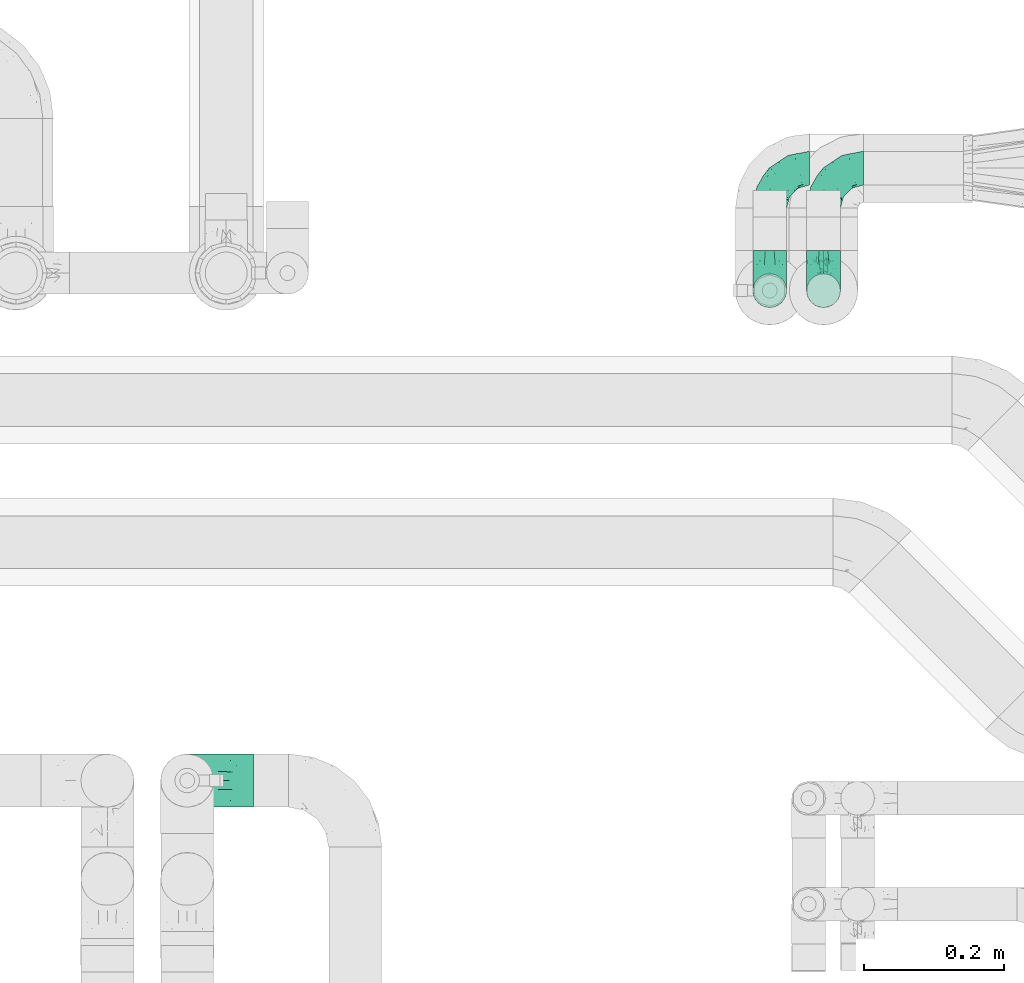
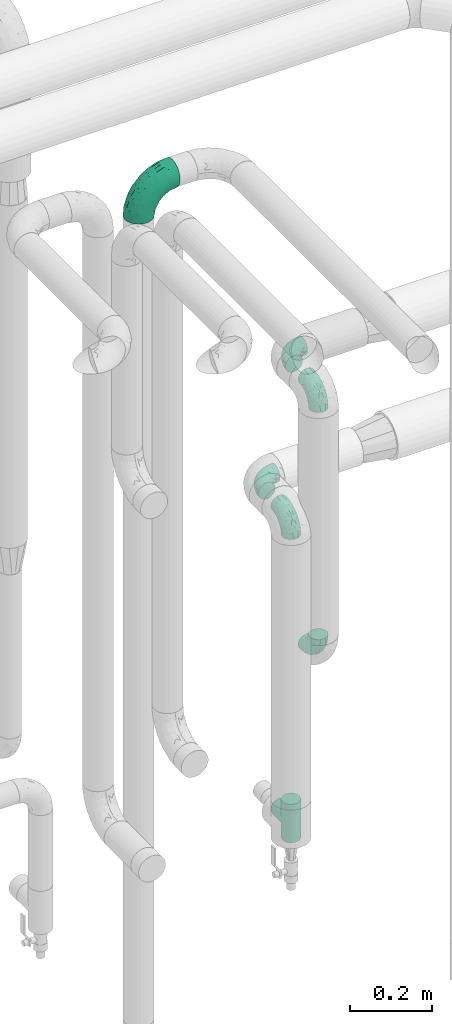
# One storey, part 681 of 824: 7 flow fittings.
"""IFC2X3 building model written with IfcOpenShell, lengths in millimetres."""

from ifc_helpers import new_model, entity, si_unit, converted_unit, derived_unit, direction, frame, origin, place, context, subcontext, project, spatial, faceted_brep, source, transform, mapped, material, type_object, type_shapes, element, save


model = new_model("IFC2X3")

# Units and contexts
model_context = context("Model", 3, precision=0.01, world=origin(), true_north=direction((6.12303176911189e-17, 1.0)))
body_context = subcontext(model_context, "Body", "Model", "MODEL_VIEW")
ifc_project = project(units=[si_unit("LENGTHUNIT", "METRE", prefix="MILLI"), si_unit("AREAUNIT", "SQUARE_METRE"), si_unit("VOLUMEUNIT", "CUBIC_METRE"), converted_unit("PLANEANGLEUNIT", "DEGREE", entity("IfcRatioMeasure", 0.0174532925199433), si_unit("PLANEANGLEUNIT", "RADIAN"), dimensions=[0, 0, 0, 0, 0, 0, 0]), si_unit("MASSUNIT", "GRAM", prefix="KILO"), derived_unit("MASSDENSITYUNIT", [(si_unit("MASSUNIT", "GRAM", prefix="KILO"), 1), (si_unit("LENGTHUNIT", "METRE"), -3)]), derived_unit("MOMENTOFINERTIAUNIT", [(si_unit("LENGTHUNIT", "METRE"), 4)]), si_unit("TIMEUNIT", "SECOND"), si_unit("FREQUENCYUNIT", "HERTZ"), si_unit("THERMODYNAMICTEMPERATUREUNIT", "DEGREE_CELSIUS"), derived_unit("THERMALTRANSMITTANCEUNIT", [(si_unit("MASSUNIT", "GRAM", prefix="KILO"), 1), (si_unit("THERMODYNAMICTEMPERATUREUNIT", "KELVIN"), -1), (si_unit("TIMEUNIT", "SECOND"), -3)]), derived_unit("VOLUMETRICFLOWRATEUNIT", [(si_unit("LENGTHUNIT", "METRE"), 3), (si_unit("TIMEUNIT", "SECOND"), -1)]), derived_unit("MASSFLOWRATEUNIT", [(si_unit("MASSUNIT", "GRAM", prefix="KILO"), 1), (si_unit("TIMEUNIT", "SECOND"), -1)]), derived_unit("ROTATIONALFREQUENCYUNIT", [(si_unit("TIMEUNIT", "SECOND"), -1)]), si_unit("ELECTRICCURRENTUNIT", "AMPERE"), si_unit("ELECTRICVOLTAGEUNIT", "VOLT"), si_unit("POWERUNIT", "WATT"), si_unit("FORCEUNIT", "NEWTON", prefix="KILO"), si_unit("ILLUMINANCEUNIT", "LUX"), si_unit("LUMINOUSFLUXUNIT", "LUMEN"), si_unit("LUMINOUSINTENSITYUNIT", "CANDELA"), derived_unit("USERDEFINED", [(si_unit("MASSUNIT", "GRAM", prefix="KILO"), -1), (si_unit("LENGTHUNIT", "METRE"), -2), (si_unit("TIMEUNIT", "SECOND"), 3), (si_unit("LUMINOUSFLUXUNIT", "LUMEN"), 1)]), derived_unit("LINEARVELOCITYUNIT", [(si_unit("LENGTHUNIT", "METRE"), 1), (si_unit("TIMEUNIT", "SECOND"), -1)]), si_unit("PRESSUREUNIT", "PASCAL"), derived_unit("USERDEFINED", [(si_unit("LENGTHUNIT", "METRE"), -2), (si_unit("MASSUNIT", "GRAM", prefix="KILO"), 1), (si_unit("TIMEUNIT", "SECOND"), -2)]), derived_unit("LINEARFORCEUNIT", [(si_unit("MASSUNIT", "GRAM", prefix="KILO"), 1), (si_unit("LENGTHUNIT", "METRE"), 1), (si_unit("TIMEUNIT", "SECOND"), -2), (si_unit("LENGTHUNIT", "METRE"), -1)]), derived_unit("PLANARFORCEUNIT", [(si_unit("MASSUNIT", "GRAM", prefix="KILO"), 1), (si_unit("LENGTHUNIT", "METRE"), 1), (si_unit("TIMEUNIT", "SECOND"), -2), (si_unit("LENGTHUNIT", "METRE"), -2)])], contexts=[model_context])

# Site, building, storey
site_placement = place(None, origin())
site = spatial("IfcSite", under=ifc_project, at=site_placement, CompositionType="ELEMENT")
building_placement = place(site_placement, origin())
building = spatial("IfcBuilding", under=site, at=building_placement, CompositionType="ELEMENT")
storey_placement = place(building_placement, frame((0.0, 0.0, 28200.0)))
storey = spatial("IfcBuildingStorey", under=building, at=storey_placement, CompositionType="ELEMENT", Elevation=28200.0)

# Flow fittings
ifc_material = material()
pipe_fitting_type_1 = type_object("IfcPipeFittingType", PredefinedType="NOTDEFINED", material=ifc_material)
shared_shape_1 = source(origin(), body_context, "Body", "Brep", [
    faceted_brep([(-57.0, 12.07, -20.91), (-57.0, 6.25, -23.33), (-57.0, 0.0, -24.15), (-57.0, -6.25, -23.33), (-57.0, -12.08, -20.91), (-57.0, -17.08, -17.08), (-57.0, -20.91, -12.08), (-57.0, -23.33, -6.25), (-57.0, -24.15, 0.0), (-57.0, -23.33, 6.25), (-57.0, -20.91, 12.07), (-57.0, -17.08, 17.08), (-57.0, -12.08, 20.91), (-57.0, -6.25, 23.33), (-57.0, 0.0, 24.15), (-57.0, 6.25, 23.33), (-57.0, 12.07, 20.91), (-57.0, 17.08, 17.08), (-57.0, 20.91, 12.07), (-57.0, 23.33, 6.25), (-57.0, 24.15, 0.0), (-57.0, 23.33, -6.25), (-57.0, 20.91, -12.08), (-57.0, 17.08, -17.08), (0.0, 57.0, -24.15), (-6.25, 57.0, -23.33), (-12.07, 57.0, -20.91), (-17.08, 57.0, -17.08), (-20.91, 57.0, -12.08), (-23.33, 57.0, -6.25), (-24.15, 57.0, 0.0), (-23.33, 57.0, 6.25), (-20.91, 57.0, 12.07), (-17.08, 57.0, 17.08), (-12.07, 57.0, 20.91), (-6.25, 57.0, 23.33), (0.0, 57.0, 24.15), (6.25, 57.0, 23.33), (12.08, 57.0, 20.91), (17.08, 57.0, 17.08), (20.91, 57.0, 12.07), (23.33, 57.0, 6.25), (24.15, 57.0, 0.0), (23.33, 57.0, -6.25), (20.91, 57.0, -12.08), (17.08, 57.0, -17.08), (12.08, 57.0, -20.91), (6.25, 57.0, -23.33), (14.9, 21.14, 6.17), (13.61, 24.64, 12.48), (6.23, 8.95, 8.98), (-41.47, -21.06, 0.0), (-41.92, -18.38, 13.72), (-24.64, -13.61, 12.48), (-37.37, -13.24, 18.15), (-6.8, -4.93, 8.18), (-21.76, -15.19, 6.22), (-12.78, -9.18, 0.0), (-37.73, -20.51, 7.75), (-7.38, 7.38, 20.24), (-23.37, -4.26, 20.42), (-11.9, -3.19, 15.86), (-42.14, -8.7, 21.82), (13.24, 37.37, 18.15), (9.33, 23.53, 16.85), (4.26, 23.37, 20.42), (2.77, 10.92, 15.55), (-29.46, 0.91, 23.52), (-44.13, 20.56, 15.69), (-39.25, 26.33, 10.88), (-49.02, 22.92, 9.96), (-34.58, 23.87, 17.15), (-15.8, 6.8, 22.81), (-8.67, 20.47, 23.88), (-18.12, 12.9, 24.08), (-48.29, 14.92, 19.65), (-44.06, -2.85, 23.78), (-9.23, 48.95, 22.58), (-3.78, 42.74, 24.07), (-40.34, 4.26, 24.09), (-44.02, 26.14, 5.46), (-44.04, 9.88, 22.74), (-4.95, 16.87, 22.52), (-2.75, 1.43, 12.5), (-25.48, 40.98, 10.71), (20.51, 37.73, 7.75), (18.38, 41.92, 13.72), (8.7, 42.14, 21.82), (-25.95, -17.97, 0.0), (2.85, 44.06, 23.78), (21.06, 41.47, 0.0), (17.97, 25.95, 0.0), (-24.04, -9.27, 17.13), (-33.26, 33.26, 5.86), (-28.55, 40.57, 0.0), (-40.57, 28.55, 0.0), (-25.29, 47.19, 4.06), (-27.01, 31.1, 16.77), (-15.7, 43.95, 19.9), (-20.27, 45.22, 15.61), (-30.53, 31.98, 12.64), (-11.28, 38.33, 22.92), (-9.97, 27.88, 24.09), (-20.15, 30.26, 21.25), (-31.25, 11.75, 23.64), (-28.75, 7.23, 24.15), (-29.53, 18.06, 22.27), (-28.44, 24.21, 20.02), (-37.55, 17.7, 20.26), (-15.88, 29.25, 22.99), (-20.82, 20.82, 23.44), (-0.91, 29.46, 23.52), (-13.5, -7.67, 12.04), (1.49, 1.56, 5.16), (8.86, 10.35, 4.59), (0.38, -0.38, 0.0), (9.18, 12.78, 0.0), (-37.37, -13.24, -18.15), (8.86, 10.35, -4.59), (-45.22, 20.27, -15.61), (-43.95, 15.7, -19.9), (-38.33, 11.28, -22.92), (-48.95, 9.23, -22.58), (-47.19, 25.29, -4.06), (-33.26, 33.26, -5.86), (18.38, 41.92, -13.72), (-30.26, 20.15, -21.25), (2.85, 44.06, -23.78), (-4.26, 40.34, -24.09), (-40.98, 25.48, -10.71), (-41.92, -18.38, -13.72), (9.25, 23.5, -16.92), (4.26, 23.37, -20.42), (13.24, 37.37, -18.15), (-37.73, -20.51, -7.75), (-11.75, 31.25, -23.64), (-7.23, 28.75, -24.15), (-12.9, 18.12, -24.08), (8.7, 42.14, -21.82), (-44.06, -2.85, -23.78), (-6.8, 15.8, -22.81), (-20.47, 8.67, -23.88), (-24.64, -13.61, -12.48), (-42.74, 3.78, -24.07), (-18.06, 29.53, -22.27), (-24.21, 28.44, -20.02), (-27.88, 9.97, -24.09), (-31.1, 27.01, -16.77), (-26.14, 44.02, -5.46), (14.9, 21.14, -6.17), (20.51, 37.73, -7.75), (-9.88, 44.04, -22.74), (-20.56, 44.13, -15.69), (-21.76, -15.19, -6.22), (-13.5, -7.67, -12.04), (-24.14, -9.76, -16.74), (-11.9, -3.19, -15.86), (-14.92, 48.29, -19.65), (-23.37, -4.26, -20.42), (-0.91, 29.46, -23.52), (-26.33, 39.25, -10.88), (-23.87, 34.58, -17.15), (-42.14, -8.7, -21.82), (-22.92, 49.02, -9.96), (13.61, 24.64, -12.48), (-31.98, 30.53, -12.64), (-16.87, 4.95, -22.52), (-17.7, 37.55, -20.26), (-29.25, 15.88, -22.99), (-20.82, 20.82, -23.44), (-29.46, 0.91, -23.52), (-7.38, 7.38, -20.24), (2.77, 10.92, -15.55), (6.23, 8.95, -8.98), (-6.8, -4.93, -8.18), (-2.81, 1.41, -12.54), (1.49, 1.56, -5.16)], [[[0, 1, 2, 3, 4, 5, 6, 7, 8, 9, 10, 11, 12, 13, 14, 15, 16, 17, 18, 19, 20, 21, 22, 23]], [[24, 25, 26, 27, 28, 29, 30, 31, 32, 33, 34, 35, 36, 37, 38, 39, 40, 41, 42, 43, 44, 45, 46, 47]], [[48, 49, 50]], [[9, 8, 51]], [[52, 53, 54]], [[55, 56, 57]], [[10, 58, 52]], [[9, 58, 10]], [[59, 60, 61]], [[54, 12, 11]], [[54, 62, 12]], [[63, 39, 38]], [[64, 65, 66]], [[62, 60, 67]], [[68, 69, 70]], [[71, 69, 68]], [[72, 73, 74]], [[16, 75, 17]], [[13, 76, 14]], [[35, 77, 78]], [[14, 79, 15]], [[17, 68, 18]], [[14, 76, 79]], [[20, 19, 80]], [[70, 19, 18]], [[81, 15, 79]], [[15, 81, 16]], [[73, 72, 82]], [[66, 83, 50]], [[32, 31, 84]], [[85, 86, 49]], [[63, 87, 65]], [[56, 58, 88]], [[36, 89, 37]], [[85, 41, 40]], [[36, 35, 78]], [[90, 41, 85]], [[40, 39, 86]], [[12, 62, 13]], [[86, 85, 40]], [[48, 85, 49]], [[85, 91, 90]], [[87, 38, 37]], [[92, 60, 54]], [[80, 69, 93]], [[93, 94, 95]], [[10, 52, 11]], [[94, 96, 30]], [[97, 98, 99]], [[80, 93, 95]], [[100, 97, 84]], [[99, 98, 33]], [[101, 102, 78]], [[103, 101, 98]], [[96, 31, 30]], [[77, 98, 101]], [[77, 35, 34]], [[34, 33, 98]], [[9, 51, 58]], [[87, 63, 38]], [[104, 105, 74]], [[106, 103, 107]], [[106, 81, 104]], [[75, 68, 17]], [[108, 107, 71]], [[33, 32, 99]], [[109, 103, 110]], [[101, 109, 102]], [[89, 78, 111]], [[53, 52, 58]], [[54, 11, 52]], [[60, 62, 54]], [[88, 58, 51]], [[76, 62, 67]], [[53, 112, 92]], [[60, 59, 72]], [[39, 63, 86]], [[49, 86, 63]], [[89, 87, 37]], [[42, 41, 90]], [[111, 82, 65]], [[111, 65, 87]], [[65, 59, 66]], [[104, 81, 79]], [[75, 81, 108]], [[32, 84, 99]], [[97, 99, 84]], [[98, 97, 103]], [[106, 107, 108]], [[74, 102, 110]], [[111, 78, 102]], [[74, 110, 104]], [[74, 67, 72]], [[61, 92, 112]], [[66, 59, 61]], [[56, 53, 58]], [[66, 50, 49]], [[61, 112, 83]], [[66, 49, 64]], [[78, 89, 36]], [[87, 89, 111]], [[62, 76, 13]], [[79, 76, 67]], [[100, 93, 69]], [[96, 93, 84]], [[55, 113, 50]], [[113, 114, 50]], [[104, 79, 105]], [[106, 104, 110]], [[20, 80, 95]], [[85, 48, 91]], [[115, 114, 113]], [[116, 91, 48]], [[70, 80, 19]], [[93, 96, 94]], [[84, 31, 96]], [[103, 106, 110]], [[81, 106, 108]], [[103, 97, 107]], [[71, 107, 97]], [[71, 97, 100]], [[108, 71, 68]], [[79, 67, 105]], [[67, 74, 105]], [[115, 113, 57]], [[112, 56, 55]], [[56, 88, 57]], [[60, 72, 67]], [[82, 72, 59]], [[65, 82, 59]], [[82, 111, 73]], [[111, 102, 73]], [[102, 74, 73]], [[81, 75, 16]], [[68, 75, 108]], [[68, 70, 18]], [[80, 70, 69]], [[98, 77, 34]], [[78, 77, 101]], [[93, 100, 84]], [[71, 100, 69]], [[102, 109, 110]], [[101, 103, 109]], [[53, 92, 54]], [[61, 60, 92]], [[56, 112, 53]], [[83, 112, 55]], [[50, 83, 55]], [[61, 83, 66]], [[49, 63, 64]], [[65, 64, 63]], [[57, 113, 55]], [[114, 115, 116]], [[116, 48, 114]], [[48, 50, 114]], [[117, 5, 4]], [[116, 115, 118]], [[119, 120, 23]], [[121, 122, 120]], [[95, 123, 20]], [[0, 23, 120]], [[124, 95, 94]], [[125, 45, 44]], [[121, 120, 126]], [[24, 127, 128]], [[22, 21, 129]], [[0, 122, 1]], [[5, 117, 130]], [[131, 132, 133]], [[134, 88, 51]], [[135, 136, 137]], [[6, 5, 130]], [[46, 138, 47]], [[139, 3, 2]], [[140, 141, 137]], [[6, 134, 7]], [[134, 130, 142]], [[143, 2, 1]], [[144, 126, 145]], [[121, 146, 143]], [[147, 120, 119]], [[94, 148, 124]], [[149, 150, 91]], [[30, 29, 148]], [[151, 25, 128]], [[27, 152, 28]], [[134, 153, 88]], [[154, 155, 156]], [[27, 26, 157]], [[151, 26, 25]], [[155, 158, 156]], [[24, 47, 127]], [[1, 122, 143]], [[138, 132, 159]], [[160, 152, 161]], [[24, 128, 25]], [[46, 133, 138]], [[162, 117, 4]], [[148, 160, 124]], [[152, 160, 163]], [[154, 142, 155]], [[45, 125, 133]], [[133, 46, 45]], [[125, 164, 133]], [[51, 7, 134]], [[42, 90, 43]], [[165, 147, 129]], [[153, 134, 142]], [[43, 150, 44]], [[162, 4, 3]], [[141, 140, 166]], [[117, 162, 158]], [[163, 29, 28]], [[43, 90, 150]], [[123, 21, 20]], [[144, 151, 135]], [[157, 152, 27]], [[167, 145, 161]], [[23, 22, 119]], [[168, 126, 169]], [[121, 168, 146]], [[139, 143, 170]], [[142, 130, 117]], [[8, 7, 51]], [[134, 6, 130]], [[139, 162, 3]], [[170, 166, 158]], [[170, 158, 162]], [[158, 171, 156]], [[44, 150, 125]], [[91, 150, 90]], [[164, 125, 150]], [[132, 138, 133]], [[127, 138, 159]], [[131, 164, 172]], [[132, 171, 140]], [[135, 151, 128]], [[157, 151, 167]], [[22, 129, 119]], [[147, 119, 129]], [[120, 147, 126]], [[144, 145, 167]], [[137, 146, 169]], [[170, 143, 146]], [[137, 169, 135]], [[137, 159, 140]], [[171, 172, 156]], [[173, 174, 175]], [[156, 175, 154]], [[174, 57, 153]], [[132, 172, 171]], [[172, 164, 173]], [[143, 139, 2]], [[162, 139, 170]], [[138, 127, 47]], [[128, 127, 159]], [[165, 124, 160]], [[123, 124, 129]], [[149, 173, 164]], [[176, 174, 173]], [[135, 128, 136]], [[144, 135, 169]], [[150, 149, 164]], [[176, 118, 115]], [[149, 91, 116]], [[30, 148, 94]], [[163, 148, 29]], [[124, 123, 95]], [[129, 21, 123]], [[126, 144, 169]], [[151, 144, 167]], [[126, 147, 145]], [[161, 145, 147]], [[161, 147, 165]], [[167, 161, 152]], [[128, 159, 136]], [[159, 137, 136]], [[154, 153, 142]], [[132, 140, 159]], [[174, 176, 57]], [[57, 88, 153]], [[166, 140, 171]], [[158, 166, 171]], [[166, 170, 141]], [[170, 146, 141]], [[146, 137, 141]], [[151, 157, 26]], [[152, 157, 167]], [[152, 163, 28]], [[148, 163, 160]], [[120, 122, 0]], [[143, 122, 121]], [[124, 165, 129]], [[161, 165, 160]], [[146, 168, 169]], [[121, 126, 168]], [[142, 117, 155]], [[158, 155, 117]], [[175, 156, 172]], [[153, 154, 174]], [[173, 175, 172]], [[174, 154, 175]], [[164, 131, 133]], [[172, 132, 131]], [[176, 173, 118]], [[57, 176, 115]], [[173, 149, 118]], [[149, 116, 118]]]),
])
type_shapes(pipe_fitting_type_1, [shared_shape_1])
for number, where, z_axis, x_axis in (
    (1, (47584.3, 19141.22, 1300.0), (0.0, 0.0, 1.0), (-1.0, 0.0, 0.0)),
    (2, (47584.3, 18966.22, 1300.0), (1.0, 0.0, 0.0), (0.0, -1.0, 0.0)),
    (3, (47661.17, 19141.22, 1650.0), (0.0, 0.0, 1.0), (-1.0, 0.0, 0.0)),
    (4, (47661.17, 18966.22, 1650.0), (1.0, 0.0, 0.0), (0.0, -1.0, 0.0)),
    (5, (47661.17, 18966.22, 861.88), (1.0, 0.0, 0.0), (0.0, 0.0, -1.0)),
):
    element("IfcFlowFitting", number, at=place(storey_placement, frame(where, z_axis=z_axis, x_axis=x_axis)), inside=storey, type_object=pipe_fitting_type_1, material=ifc_material, context=body_context, shape_type="MappedRepresentation", body=[
        mapped(shared_shape_1, transform((0.0, 0.0, 0.0), scale=1.0)),
    ])
pipe_fitting_type_2 = type_object("IfcPipeFittingType", PredefinedType="NOTDEFINED", material=ifc_material)
shared_shape_2 = source(origin(), body_context, "Body", "Brep", [
    faceted_brep([(-57.0, 12.07, -20.91), (-57.0, 6.25, -23.33), (-57.0, 0.0, -24.15), (-57.0, -6.25, -23.33), (-57.0, -12.08, -20.91), (-57.0, -17.08, -17.08), (-57.0, -20.91, -12.08), (-57.0, -23.33, -6.25), (-57.0, -24.15, 0.0), (-57.0, -23.33, 6.25), (-57.0, -20.91, 12.07), (-57.0, -17.08, 17.08), (-57.0, -12.08, 20.91), (-57.0, -6.25, 23.33), (-57.0, 0.0, 24.15), (-57.0, 6.25, 23.33), (-57.0, 12.07, 20.91), (-57.0, 17.08, 17.08), (-57.0, 20.91, 12.07), (-57.0, 23.33, 6.25), (-57.0, 24.15, 0.0), (-57.0, 23.33, -6.25), (-57.0, 20.91, -12.08), (-57.0, 17.08, -17.08), (57.0, 0.0, -24.15), (57.0, 6.25, -23.33), (57.0, 12.07, -20.91), (57.0, 17.08, -17.08), (57.0, 20.91, -12.08), (57.0, 23.33, -6.25), (57.0, 24.15, 0.0), (57.0, 23.33, 6.25), (57.0, 20.91, 12.07), (57.0, 17.08, 17.08), (57.0, 12.07, 20.91), (57.0, 6.25, 23.33), (57.0, 0.0, 24.15), (57.0, -6.25, 23.33), (57.0, -12.08, 20.91), (57.0, -17.08, 17.08), (57.0, -20.91, 12.07), (57.0, -23.33, 6.25), (57.0, -24.15, 0.0), (57.0, -23.33, -6.25), (57.0, -20.91, -12.08), (57.0, -17.08, -17.08), (57.0, -12.08, -20.91), (57.0, -6.25, -23.33), (23.27, -23.27, 6.45), (24.15, -24.15, 0.0), (-24.15, -24.15, 0.0), (20.9, -20.9, 12.1), (13.54, -13.54, 20.0), (17.52, -17.52, 16.62), (-23.27, -23.27, 6.45), (-20.9, -20.9, 12.1), (-17.52, -17.52, 16.62), (-13.54, -13.54, 20.0), (-9.19, -9.19, 22.33), (9.19, -9.19, 22.33), (4.64, -4.64, 23.7), (0.0, 0.0, 24.15), (-4.64, -4.64, 23.7), (4.64, -4.64, -23.7), (0.0, 0.0, -24.15), (-4.64, -4.64, -23.7), (-9.19, -9.19, -22.33), (9.19, -9.19, -22.33), (13.54, -13.54, -20.0), (17.52, -17.52, -16.62), (20.9, -20.9, -12.1), (23.27, -23.27, -6.45), (-13.54, -13.54, -20.0), (-17.52, -17.52, -16.62), (-23.27, -23.27, -6.45), (-20.9, -20.9, -12.1), (0.0, -57.0, -24.15), (6.25, -57.0, -23.33), (12.08, -57.0, -20.91), (17.08, -57.0, -17.08), (20.91, -57.0, -12.08), (23.33, -57.0, -6.25), (24.15, -57.0, 0.0), (23.33, -57.0, 6.25), (20.91, -57.0, 12.07), (17.08, -57.0, 17.08), (12.08, -57.0, 20.91), (6.25, -57.0, 23.33), (0.0, -57.0, 24.15), (-6.25, -57.0, 23.33), (-12.07, -57.0, 20.91), (-17.08, -57.0, 17.08), (-20.91, -57.0, 12.07), (-23.33, -57.0, 6.25), (-24.15, -57.0, 0.0), (-23.33, -57.0, -6.25), (-20.91, -57.0, -12.08), (-17.08, -57.0, -17.08), (-12.07, -57.0, -20.91), (-6.25, -57.0, -23.33)], [[[0, 1, 2, 3, 4, 5, 6, 7, 8, 9, 10, 11, 12, 13, 14, 15, 16, 17, 18, 19, 20, 21, 22, 23]], [[24, 25, 26, 27, 28, 29, 30, 31, 32, 33, 34, 35, 36, 37, 38, 39, 40, 41, 42, 43, 44, 45, 46, 47]], [[41, 40, 48]], [[42, 41, 49]], [[50, 9, 8]], [[49, 41, 48]], [[40, 51, 48]], [[39, 38, 52]], [[51, 40, 53]], [[52, 53, 39]], [[53, 40, 39]], [[50, 54, 9]], [[9, 54, 10]], [[54, 55, 10]], [[56, 57, 11]], [[11, 10, 56]], [[11, 57, 12]], [[56, 10, 55]], [[12, 57, 58]], [[52, 38, 59]], [[60, 36, 61]], [[62, 61, 14]], [[59, 37, 60]], [[37, 59, 38]], [[60, 37, 36]], [[61, 36, 35, 15, 14]], [[32, 31, 19, 18]], [[17, 16, 34, 33]], [[18, 17, 33, 32]], [[35, 34, 16, 15]], [[20, 19, 31, 30]], [[62, 13, 58]], [[13, 62, 14]], [[58, 13, 12]], [[27, 23, 22, 28]], [[22, 21, 29, 28]], [[0, 23, 27, 26]], [[20, 30, 29, 21]], [[24, 47, 63]], [[24, 64, 2, 1, 25]], [[64, 24, 63]], [[2, 64, 65]], [[26, 25, 1, 0]], [[65, 66, 3]], [[2, 65, 3]], [[66, 4, 3]], [[63, 47, 67]], [[46, 45, 68]], [[69, 68, 45]], [[44, 70, 69]], [[69, 45, 44]], [[46, 68, 67]], [[43, 42, 49]], [[7, 50, 8]], [[43, 71, 44]], [[71, 43, 49]], [[44, 71, 70]], [[72, 4, 66]], [[72, 5, 4]], [[5, 72, 73]], [[5, 73, 6]], [[74, 50, 7]], [[75, 74, 6]], [[74, 7, 6]], [[75, 6, 73]], [[46, 67, 47]], [[76, 77, 78, 79, 80, 81, 82, 83, 84, 85, 86, 87, 88, 89, 90, 91, 92, 93, 94, 95, 96, 97, 98, 99]], [[50, 94, 93]], [[54, 50, 93]], [[91, 90, 57]], [[56, 92, 91]], [[54, 93, 92]], [[58, 90, 89]], [[55, 54, 92]], [[56, 55, 92]], [[58, 57, 90]], [[88, 61, 62]], [[58, 89, 62]], [[56, 91, 57]], [[62, 89, 88]], [[60, 88, 87]], [[86, 59, 87]], [[84, 83, 48]], [[53, 85, 84]], [[52, 86, 85]], [[49, 83, 82]], [[59, 60, 87]], [[52, 59, 86]], [[49, 48, 83]], [[51, 53, 84]], [[48, 51, 84]], [[52, 85, 53]], [[88, 60, 61]], [[82, 81, 49]], [[71, 49, 81]], [[69, 80, 79]], [[79, 78, 68]], [[71, 81, 80]], [[67, 78, 77]], [[70, 71, 80]], [[69, 70, 80]], [[67, 68, 78]], [[76, 64, 63]], [[67, 77, 63]], [[69, 79, 68]], [[63, 77, 76]], [[65, 76, 99]], [[98, 66, 99]], [[96, 95, 74]], [[73, 97, 96]], [[72, 98, 97]], [[50, 95, 94]], [[66, 65, 99]], [[72, 66, 98]], [[50, 74, 95]], [[75, 73, 96]], [[74, 75, 96]], [[72, 97, 73]], [[76, 65, 64]]]),
])
type_shapes(pipe_fitting_type_2, [shared_shape_2])
flow_fitting_1_placement = place(storey_placement, frame((47584.3, 18966.22, 400.0), z_axis=(-1.0, 0.0, 0.0), x_axis=(0.0, 0.0, -1.0)))
element("IfcFlowFitting", 6, at=flow_fitting_1_placement, inside=storey, type_object=pipe_fitting_type_2, material=ifc_material, context=body_context, shape_type="MappedRepresentation", body=[
    mapped(shared_shape_2, transform((0.0, 0.0, 0.0), scale=1.0)),
])
pipe_fitting_type_3 = type_object("IfcPipeFittingType", PredefinedType="NOTDEFINED", material=ifc_material)
shared_shape_3 = source(origin(), body_context, "Body", "Brep", [
    faceted_brep([(-95.0, 19.02, -32.95), (-95.0, 9.85, -36.75), (-95.0, 0.0, -38.05), (-95.0, -9.85, -36.75), (-95.0, -19.03, -32.95), (-95.0, -26.91, -26.91), (-95.0, -32.95, -19.03), (-95.0, -36.75, -9.85), (-95.0, -38.05, 0.0), (-95.0, -36.75, 9.85), (-95.0, -32.95, 19.02), (-95.0, -26.91, 26.91), (-95.0, -19.03, 32.95), (-95.0, -9.85, 36.75), (-95.0, 0.0, 38.05), (-95.0, 9.85, 36.75), (-95.0, 19.02, 32.95), (-95.0, 26.91, 26.91), (-95.0, 32.95, 19.02), (-95.0, 36.75, 9.85), (-95.0, 38.05, 0.0), (-95.0, 36.75, -9.85), (-95.0, 32.95, -19.03), (-95.0, 26.91, -26.91), (0.0, 95.0, -38.05), (-9.85, 95.0, -36.75), (-19.02, 95.0, -32.95), (-26.91, 95.0, -26.91), (-32.95, 95.0, -19.03), (-36.75, 95.0, -9.85), (-38.05, 95.0, 0.0), (-36.75, 95.0, 9.85), (-32.95, 95.0, 19.02), (-26.91, 95.0, 26.91), (-19.02, 95.0, 32.95), (-9.85, 95.0, 36.75), (0.0, 95.0, 38.05), (9.85, 95.0, 36.75), (19.03, 95.0, 32.95), (26.91, 95.0, 26.91), (32.95, 95.0, 19.02), (36.75, 95.0, 9.85), (38.05, 95.0, 0.0), (36.75, 95.0, -9.85), (32.95, 95.0, -19.03), (26.91, 95.0, -26.91), (19.03, 95.0, -32.95), (9.85, 95.0, -36.75), (-7.99, -4.96, 6.3), (-0.92, 0.92, 0.0), (4.62, 8.1, 8.01), (-76.19, -35.57, 0.0), (-64.32, -32.32, 12.43), (20.51, 62.45, 28.68), (-60.56, -33.52, 0.0), (-70.4, -13.47, 34.42), (-39.61, -5.88, 32.32), (-49.6, 2.07, 37.1), (-70.34, -28.81, 21.71), (14.64, 40.81, 26.5), (5.88, 39.61, 32.32), (3.59, 20.77, 25.31), (-40.45, 68.06, 16.75), (-62.45, -20.51, 28.68), (-44.52, -26.87, 0.0), (-28.47, -20.22, 0.0), (-26.43, -17.83, 8.75), (-76.1, 39.63, 10.76), (-72.74, 37.58, 18.19), (-60.35, 46.18, 14.61), (-13.4, 13.4, 32.12), (-20.77, -3.59, 25.31), (-14.66, 81.47, 35.56), (-6.22, 71.26, 37.92), (-57.5, 42.48, 22.79), (-15.0, 34.74, 37.7), (-27.1, 12.08, 36.05), (-9.2, 28.81, 35.63), (-79.98, 23.7, 30.95), (-73.68, -4.3, 37.48), (-30.74, 21.67, 37.97), (-62.36, 47.59, 6.79), (-72.71, 32.83, 24.69), (-67.42, 7.02, 37.95), (-32.13, 75.27, 24.51), (-43.46, 51.47, 26.26), (-24.98, 73.15, 31.29), (20.59, 41.28, 19.85), (7.79, 16.09, 15.86), (-73.21, 42.39, 0.0), (-54.73, 54.73, 0.0), (-73.44, 15.79, 35.79), (-5.94, 4.32, 20.43), (28.81, 70.34, 21.71), (32.32, 64.32, 12.43), (-53.59, 26.2, 35.09), (-52.02, 19.31, 37.21), (21.38, 33.53, 10.34), (26.87, 44.52, 0.0), (-48.28, 12.14, 38.05), (4.3, 73.68, 37.48), (-44.08, -25.52, 12.79), (-41.28, -20.59, 19.85), (35.57, 76.19, 0.0), (-47.26, 54.3, 20.18), (-47.4, 61.99, 8.58), (-42.39, 73.21, 0.0), (-39.67, 78.86, 7.21), (-45.69, 36.84, 33.11), (-32.83, 50.13, 33.35), (13.47, 70.4, 34.42), (-18.25, 63.73, 36.07), (-40.63, -13.75, 27.22), (-16.63, 46.37, 37.95), (-53.47, 38.79, 28.59), (-26.07, 48.54, 36.15), (-34.51, 34.51, 36.86), (-2.07, 49.6, 37.1), (-22.79, -10.49, 19.23), (-61.73, 28.67, 31.87), (9.65, 14.7, 0.0), (20.22, 28.47, 0.0), (33.52, 60.56, 0.0), (-11.42, -5.44, 13.25), (-14.7, -9.65, 0.0), (-81.47, 14.66, -35.56), (-62.45, -20.51, -28.68), (-71.26, 6.22, -37.92), (-75.27, 32.13, -24.51), (-73.15, 24.98, -31.29), (13.47, 70.4, -34.42), (5.88, 39.61, -32.32), (-2.07, 49.6, -37.1), (-78.86, 39.67, -7.21), (-70.4, -13.47, -34.42), (-39.61, -5.88, -32.32), (-61.99, 47.4, -8.58), (32.32, 64.32, -12.43), (28.81, 70.34, -21.71), (-63.73, 18.25, -36.07), (-50.13, 32.83, -33.35), (4.3, 73.68, -37.48), (-7.02, 67.42, -37.95), (-39.63, 76.1, -10.76), (-46.18, 60.35, -14.61), (-47.59, 62.36, -6.79), (-64.32, -32.32, -12.43), (-26.2, 53.59, -35.09), (-15.79, 73.44, -35.79), (-19.31, 52.02, -37.21), (-37.58, 72.74, -18.19), (-70.34, -28.81, -21.71), (-42.48, 57.5, -22.79), (-38.79, 53.47, -28.59), (-51.47, 43.46, -26.26), (-32.83, 72.71, -24.69), (-46.37, 16.63, -37.95), (-73.68, -4.3, -37.48), (-41.28, -20.59, -19.85), (-44.08, -25.52, -12.79), (13.75, 40.63, -27.22), (20.51, 62.45, -28.68), (-68.06, 40.45, -16.75), (-54.3, 47.26, -20.18), (-12.14, 48.28, -38.05), (-21.67, 30.74, -37.97), (-36.84, 45.69, -33.11), (-11.42, -5.44, -13.25), (7.79, 16.09, -15.86), (4.62, 8.1, -8.01), (-23.7, 79.98, -30.95), (-26.43, -17.83, -8.75), (-7.99, -4.96, -6.3), (-40.81, -14.64, -26.5), (-20.77, -3.59, -25.31), (-34.74, 15.0, -37.7), (-12.08, 27.1, -36.05), (-28.81, 9.2, -35.63), (-22.79, -10.49, -19.23), (21.38, 33.53, -10.34), (20.59, 41.28, -19.85), (-48.54, 26.07, -36.15), (-49.6, 2.07, -37.1), (-13.4, 13.4, -32.12), (3.59, 20.77, -25.31), (-28.67, 61.73, -31.87), (-34.51, 34.51, -36.86), (-5.94, 4.32, -20.43)], [[[0, 1, 2, 3, 4, 5, 6, 7, 8, 9, 10, 11, 12, 13, 14, 15, 16, 17, 18, 19, 20, 21, 22, 23]], [[24, 25, 26, 27, 28, 29, 30, 31, 32, 33, 34, 35, 36, 37, 38, 39, 40, 41, 42, 43, 44, 45, 46, 47]], [[48, 49, 50]], [[51, 52, 9]], [[53, 39, 38]], [[9, 52, 10]], [[54, 52, 51]], [[55, 56, 57]], [[11, 10, 58]], [[59, 60, 61]], [[32, 31, 62]], [[63, 12, 11]], [[63, 55, 12]], [[64, 65, 66]], [[67, 68, 69]], [[70, 56, 71]], [[35, 72, 73]], [[69, 68, 74]], [[75, 76, 77]], [[16, 78, 17]], [[13, 79, 14]], [[76, 75, 80]], [[67, 69, 81]], [[18, 17, 82]], [[14, 79, 83]], [[20, 19, 67]], [[84, 85, 86]], [[87, 61, 88]], [[89, 81, 90]], [[18, 82, 68]], [[15, 91, 16]], [[14, 83, 15]], [[71, 92, 61]], [[17, 78, 82]], [[93, 87, 94]], [[95, 91, 96]], [[97, 98, 94]], [[86, 72, 34]], [[96, 99, 80]], [[37, 36, 100]], [[40, 39, 93]], [[40, 94, 41]], [[64, 66, 101]], [[93, 94, 40]], [[58, 102, 63]], [[94, 103, 41]], [[94, 87, 97]], [[104, 69, 74]], [[34, 33, 86]], [[105, 69, 104]], [[52, 58, 10]], [[106, 107, 30]], [[108, 109, 85]], [[105, 106, 90]], [[53, 110, 60]], [[86, 111, 72]], [[86, 109, 111]], [[33, 84, 86]], [[12, 55, 13]], [[112, 56, 63]], [[110, 38, 37]], [[34, 72, 35]], [[36, 35, 73]], [[111, 113, 73]], [[105, 107, 106]], [[110, 53, 38]], [[74, 114, 85]], [[91, 15, 83]], [[105, 90, 81]], [[107, 62, 31]], [[33, 32, 84]], [[115, 109, 116]], [[111, 115, 113]], [[100, 73, 117]], [[56, 55, 63]], [[79, 55, 57]], [[102, 118, 112]], [[56, 70, 76]], [[100, 110, 37]], [[117, 77, 60]], [[117, 60, 110]], [[60, 70, 61]], [[58, 52, 101]], [[63, 11, 58]], [[39, 53, 93]], [[87, 93, 53]], [[96, 91, 83]], [[78, 91, 119]], [[32, 62, 84]], [[84, 62, 104]], [[86, 85, 109]], [[85, 114, 108]], [[80, 113, 116]], [[117, 73, 113]], [[80, 116, 96]], [[80, 57, 76]], [[71, 112, 118]], [[61, 87, 59]], [[62, 107, 105]], [[97, 120, 121]], [[70, 71, 61]], [[71, 118, 92]], [[73, 100, 36]], [[110, 100, 117]], [[55, 79, 13]], [[83, 79, 57]], [[96, 83, 99]], [[116, 108, 95]], [[50, 97, 88]], [[97, 87, 88]], [[50, 49, 120]], [[122, 94, 98]], [[89, 20, 67]], [[105, 81, 69]], [[89, 67, 81]], [[68, 19, 18]], [[68, 67, 19]], [[74, 68, 82]], [[114, 82, 119]], [[74, 85, 104]], [[82, 114, 74]], [[114, 119, 108]], [[95, 108, 119]], [[116, 109, 108]], [[123, 48, 50]], [[97, 50, 120]], [[123, 50, 88]], [[91, 95, 119]], [[116, 95, 96]], [[84, 104, 85]], [[104, 62, 105]], [[83, 57, 99]], [[57, 80, 99]], [[66, 48, 123]], [[66, 124, 48]], [[118, 66, 123]], [[124, 66, 65]], [[66, 118, 101]], [[54, 64, 52]], [[124, 49, 48]], [[30, 107, 31]], [[91, 78, 16]], [[82, 78, 119]], [[56, 76, 57]], [[77, 76, 70]], [[60, 77, 70]], [[77, 117, 75]], [[117, 113, 75]], [[113, 80, 75]], [[9, 8, 51]], [[103, 94, 122]], [[103, 42, 41]], [[73, 72, 111]], [[113, 115, 116]], [[111, 109, 115]], [[102, 112, 63]], [[71, 56, 112]], [[118, 102, 101]], [[92, 123, 88]], [[123, 92, 118]], [[61, 92, 88]], [[87, 53, 59]], [[60, 59, 53]], [[97, 121, 98]], [[58, 101, 102]], [[64, 101, 52]], [[125, 1, 0]], [[126, 5, 4]], [[2, 1, 127]], [[1, 125, 127]], [[128, 129, 23]], [[130, 131, 132]], [[89, 133, 20]], [[126, 134, 135]], [[136, 89, 90]], [[137, 138, 44]], [[139, 129, 140]], [[24, 141, 142]], [[143, 144, 145]], [[125, 129, 139]], [[6, 146, 7]], [[147, 148, 149]], [[146, 51, 7]], [[143, 150, 144]], [[146, 6, 151]], [[152, 153, 154]], [[126, 4, 134]], [[0, 23, 129]], [[28, 155, 150]], [[43, 42, 103]], [[54, 146, 64]], [[139, 156, 127]], [[157, 3, 2]], [[151, 158, 159]], [[160, 131, 161]], [[22, 21, 162]], [[136, 144, 163]], [[149, 164, 165]], [[24, 142, 25]], [[166, 140, 154]], [[154, 129, 128]], [[143, 30, 29]], [[167, 168, 169]], [[155, 28, 27]], [[26, 170, 27]], [[171, 167, 172]], [[26, 25, 148]], [[27, 170, 155]], [[173, 135, 174]], [[144, 150, 152]], [[175, 176, 177]], [[24, 47, 141]], [[45, 161, 46]], [[148, 25, 142]], [[176, 175, 165]], [[64, 159, 171]], [[138, 45, 44]], [[130, 46, 161]], [[137, 44, 43]], [[178, 159, 158]], [[137, 103, 122]], [[163, 144, 152]], [[136, 133, 89]], [[103, 137, 43]], [[6, 5, 151]], [[178, 158, 173]], [[134, 4, 3]], [[178, 173, 174]], [[137, 98, 179]], [[145, 90, 106]], [[138, 180, 161]], [[46, 130, 47]], [[136, 90, 145]], [[133, 162, 21]], [[23, 22, 128]], [[139, 140, 181]], [[139, 181, 156]], [[157, 127, 182]], [[157, 134, 3]], [[182, 177, 135]], [[182, 135, 134]], [[135, 183, 174]], [[131, 130, 161]], [[141, 130, 132]], [[160, 180, 184]], [[131, 183, 176]], [[5, 126, 151]], [[158, 151, 126]], [[180, 138, 137]], [[161, 45, 138]], [[149, 148, 142]], [[170, 148, 185]], [[22, 162, 128]], [[128, 162, 163]], [[129, 154, 140]], [[154, 153, 166]], [[165, 156, 186]], [[182, 127, 156]], [[165, 186, 149]], [[165, 132, 176]], [[131, 184, 183]], [[187, 167, 178]], [[184, 168, 187]], [[167, 169, 172]], [[184, 180, 168]], [[174, 183, 184]], [[127, 157, 2]], [[134, 157, 182]], [[130, 141, 47]], [[142, 141, 132]], [[149, 142, 164]], [[186, 166, 147]], [[180, 179, 168]], [[169, 179, 120]], [[137, 179, 180]], [[179, 121, 120]], [[106, 30, 143]], [[136, 145, 144]], [[106, 143, 145]], [[150, 29, 28]], [[150, 143, 29]], [[152, 150, 155]], [[153, 155, 185]], [[152, 154, 163]], [[155, 153, 152]], [[153, 185, 166]], [[147, 166, 185]], [[186, 140, 166]], [[169, 120, 49]], [[169, 49, 172]], [[179, 169, 168]], [[148, 147, 185]], [[186, 147, 149]], [[128, 163, 154]], [[163, 162, 136]], [[142, 132, 164]], [[132, 165, 164]], [[171, 124, 65]], [[124, 171, 172]], [[64, 146, 159]], [[171, 159, 178]], [[171, 65, 64]], [[172, 49, 124]], [[162, 133, 136]], [[20, 133, 21]], [[148, 170, 26]], [[155, 170, 185]], [[131, 176, 132]], [[177, 176, 183]], [[135, 177, 183]], [[177, 182, 175]], [[182, 156, 175]], [[156, 165, 175]], [[51, 146, 54]], [[51, 8, 7]], [[129, 125, 0]], [[127, 125, 139]], [[140, 186, 181]], [[156, 181, 186]], [[158, 126, 173]], [[135, 173, 126]], [[187, 178, 174]], [[171, 178, 167]], [[184, 187, 174]], [[167, 187, 168]], [[180, 160, 161]], [[184, 131, 160]], [[98, 137, 122]], [[98, 121, 179]], [[151, 159, 146]]]),
])
type_shapes(pipe_fitting_type_3, [shared_shape_3])
flow_fitting_2_placement = place(storey_placement, frame((46752.07, 18266.24, 3000.0), z_axis=(0.0, -1.0, 0.0), x_axis=(-1.0, 0.0, 0.0)))
element("IfcFlowFitting", 7, at=flow_fitting_2_placement, inside=storey, type_object=pipe_fitting_type_3, material=ifc_material, context=body_context, shape_type="MappedRepresentation", body=[
    mapped(shared_shape_3, transform((0.0, 0.0, 0.0), scale=1.0)),
])

save(model, "model.ifc")
